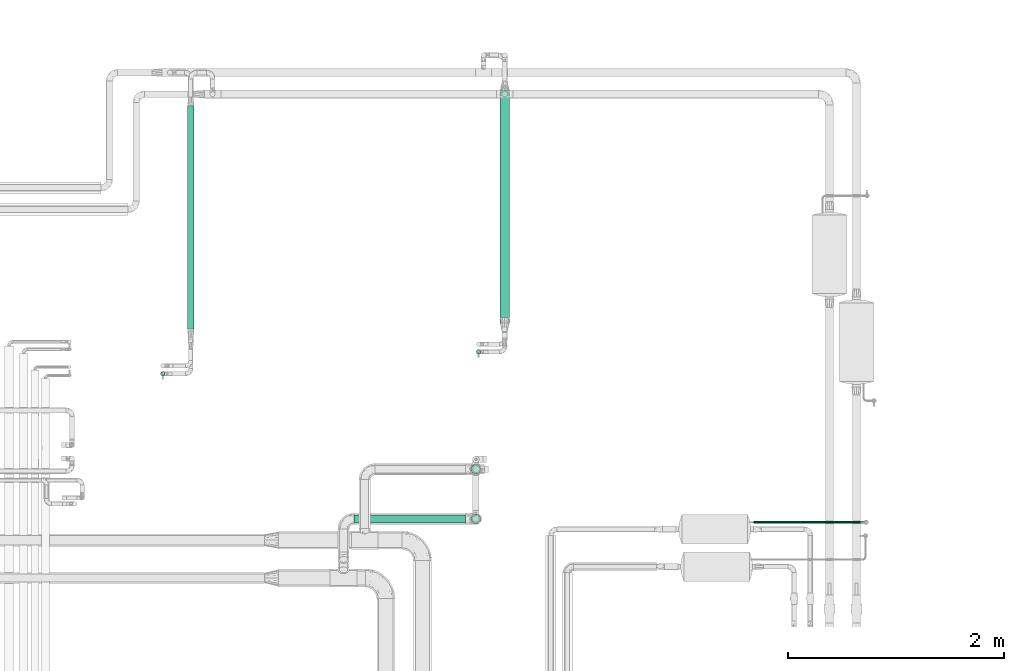
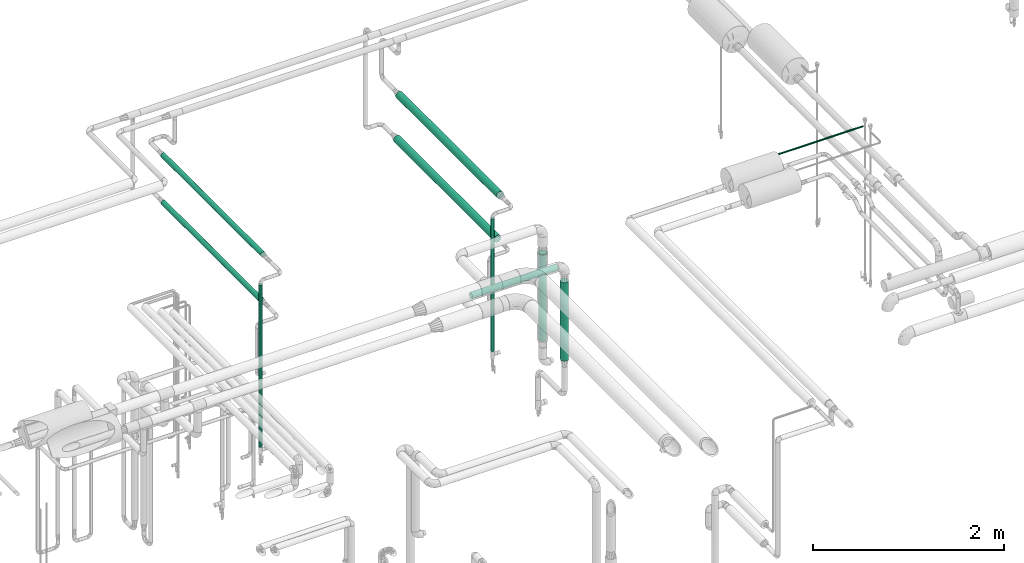
# One storey, part 527 of 827: 10 flow segments.
"""IFC2X3 building model written with IfcOpenShell, lengths in millimetres."""

from ifc_helpers import new_model, entity, si_unit, converted_unit, derived_unit, direction, frame, origin, origin_2d_with_axis, place, context, subcontext, project, spatial, circle, extrude, type_object, element, save


model = new_model("IFC2X3")

# Units and contexts
model_context = context("Model", 3, precision=0.01, world=origin(), true_north=direction((6.12303176911189e-17, 1.0)))
body_context = subcontext(model_context, "Body", "Model", "MODEL_VIEW")
ifc_project = project(units=[si_unit("LENGTHUNIT", "METRE", prefix="MILLI"), si_unit("AREAUNIT", "SQUARE_METRE"), si_unit("VOLUMEUNIT", "CUBIC_METRE"), converted_unit("PLANEANGLEUNIT", "DEGREE", entity("IfcRatioMeasure", 0.0174532925199433), si_unit("PLANEANGLEUNIT", "RADIAN"), dimensions=[0, 0, 0, 0, 0, 0, 0]), si_unit("MASSUNIT", "GRAM", prefix="KILO"), derived_unit("MASSDENSITYUNIT", [(si_unit("MASSUNIT", "GRAM", prefix="KILO"), 1), (si_unit("LENGTHUNIT", "METRE"), -3)]), derived_unit("MOMENTOFINERTIAUNIT", [(si_unit("LENGTHUNIT", "METRE"), 4)]), si_unit("TIMEUNIT", "SECOND"), si_unit("FREQUENCYUNIT", "HERTZ"), si_unit("THERMODYNAMICTEMPERATUREUNIT", "DEGREE_CELSIUS"), derived_unit("THERMALTRANSMITTANCEUNIT", [(si_unit("MASSUNIT", "GRAM", prefix="KILO"), 1), (si_unit("THERMODYNAMICTEMPERATUREUNIT", "KELVIN"), -1), (si_unit("TIMEUNIT", "SECOND"), -3)]), derived_unit("VOLUMETRICFLOWRATEUNIT", [(si_unit("LENGTHUNIT", "METRE"), 3), (si_unit("TIMEUNIT", "SECOND"), -1)]), derived_unit("MASSFLOWRATEUNIT", [(si_unit("MASSUNIT", "GRAM", prefix="KILO"), 1), (si_unit("TIMEUNIT", "SECOND"), -1)]), derived_unit("ROTATIONALFREQUENCYUNIT", [(si_unit("TIMEUNIT", "SECOND"), -1)]), si_unit("ELECTRICCURRENTUNIT", "AMPERE"), si_unit("ELECTRICVOLTAGEUNIT", "VOLT"), si_unit("POWERUNIT", "WATT"), si_unit("FORCEUNIT", "NEWTON", prefix="KILO"), si_unit("ILLUMINANCEUNIT", "LUX"), si_unit("LUMINOUSFLUXUNIT", "LUMEN"), si_unit("LUMINOUSINTENSITYUNIT", "CANDELA"), derived_unit("USERDEFINED", [(si_unit("MASSUNIT", "GRAM", prefix="KILO"), -1), (si_unit("LENGTHUNIT", "METRE"), -2), (si_unit("TIMEUNIT", "SECOND"), 3), (si_unit("LUMINOUSFLUXUNIT", "LUMEN"), 1)]), derived_unit("LINEARVELOCITYUNIT", [(si_unit("LENGTHUNIT", "METRE"), 1), (si_unit("TIMEUNIT", "SECOND"), -1)]), si_unit("PRESSUREUNIT", "PASCAL"), derived_unit("USERDEFINED", [(si_unit("LENGTHUNIT", "METRE"), -2), (si_unit("MASSUNIT", "GRAM", prefix="KILO"), 1), (si_unit("TIMEUNIT", "SECOND"), -2)]), derived_unit("LINEARFORCEUNIT", [(si_unit("MASSUNIT", "GRAM", prefix="KILO"), 1), (si_unit("LENGTHUNIT", "METRE"), 1), (si_unit("TIMEUNIT", "SECOND"), -2), (si_unit("LENGTHUNIT", "METRE"), -1)]), derived_unit("PLANARFORCEUNIT", [(si_unit("MASSUNIT", "GRAM", prefix="KILO"), 1), (si_unit("LENGTHUNIT", "METRE"), 1), (si_unit("TIMEUNIT", "SECOND"), -2), (si_unit("LENGTHUNIT", "METRE"), -2)])], contexts=[model_context])

# Site, building, storey
site_placement = place(None, origin())
site = spatial("IfcSite", under=ifc_project, at=site_placement, CompositionType="ELEMENT")
building_placement = place(site_placement, origin())
building = spatial("IfcBuilding", under=site, at=building_placement, CompositionType="ELEMENT")
storey_placement = place(building_placement, frame((0.0, 0.0, 28200.0)))
storey = spatial("IfcBuildingStorey", under=building, at=storey_placement, Name="08", CompositionType="ELEMENT", Elevation=28200.0)

# Flow segments
pipe_segment_type = type_object("IfcPipeSegmentType", PredefinedType="NOTDEFINED")
flow_segment_1_placement = place(storey_placement, frame((19747.74, 16268.55, 477.5)))
element("IfcFlowSegment", 1, at=flow_segment_1_placement, inside=storey, type_object=pipe_segment_type, context=body_context, shape_type="SweptSolid", body=[
    extrude(circle(Radius=21.15, at=origin_2d_with_axis()), frame((22.75, 22.75, 0.0), z_axis=(0.0, 0.0, 1.0), x_axis=(-1.0, 0.0, 0.0)), (0.0, 0.0, 1.0), 2074.83074715792),
])
flow_segment_2_placement = place(storey_placement, frame((22670.89, 16471.77, 553.82)))
element("IfcFlowSegment", 2, at=flow_segment_2_placement, inside=storey, type_object=pipe_segment_type, context=body_context, shape_type="SweptSolid", body=[
    extrude(circle(Radius=21.15, at=origin_2d_with_axis()), frame((22.75, 22.75, 0.0)), (0.0, 0.0, 1.0), 1695.43871126385),
])
flow_segment_3_placement = place(storey_placement, frame((21538.56, 14907.9, 2560.65)))
element("IfcFlowSegment", 3, at=flow_segment_3_placement, inside=storey, type_object=pipe_segment_type, context=body_context, shape_type="SweptSolid", body=[
    extrude(circle(Radius=37.75, at=origin_2d_with_axis()), frame((0.0, 39.35, 39.35), z_axis=(1.0, 0.0, 0.0), x_axis=(0.0, -1.0, 0.0)), (0.0, 0.0, 1.0), 1035.89794397964),
])
flow_segment_4_placement = place(storey_placement, frame((25238.71, 14903.34, 3117.75)))
element("IfcFlowSegment", 4, at=flow_segment_4_placement, inside=storey, type_object=pipe_segment_type, context=body_context, shape_type="SweptSolid", body=[
    extrude(circle(Radius=10.65, at=origin_2d_with_axis()), frame((0.0, 12.25, 12.25), z_axis=(1.0, 0.0, 0.0), x_axis=(0.0, 1.0, 0.0)), (0.0, 0.0, 1.0), 1019.58795672273),
])
flow_segment_5_placement = place(storey_placement, frame((22623.61, 15361.4, 1369.89)))
element("IfcFlowSegment", 5, at=flow_segment_5_placement, inside=storey, type_object=pipe_segment_type, context=body_context, shape_type="SweptSolid", body=[
    extrude(circle(Radius=44.25, at=origin_2d_with_axis()), frame((45.85, 45.85, 0.0)), (0.0, 0.0, 1.0), 1110.0),
])
flow_segment_6_placement = place(storey_placement, frame((22890.62, 16761.47, 2251.42)))
element("IfcFlowSegment", 6, at=flow_segment_6_placement, inside=storey, type_object=pipe_segment_type, context=body_context, shape_type="SweptSolid", body=[
    extrude(circle(Radius=44.25, at=origin_2d_with_axis()), frame((45.85, 0.0, 45.85), z_axis=(0.0, 1.0, 0.0), x_axis=(-1.0, 0.0, 0.0)), (0.0, 0.0, 1.0), 2106.00000000002),
])
flow_segment_7_placement = place(storey_placement, frame((22890.62, 16811.3, 1661.21)))
element("IfcFlowSegment", 7, at=flow_segment_7_placement, inside=storey, type_object=pipe_segment_type, context=body_context, shape_type="SweptSolid", body=[
    extrude(circle(Radius=44.25, at=origin_2d_with_axis()), frame((45.85, 0.0, 45.85), z_axis=(0.0, 1.0, 0.0), x_axis=(-1.0, 0.0, 0.0)), (0.0, 0.0, 1.0), 2103.50000000002),
])
flow_segment_8_placement = place(storey_placement, frame((22623.61, 14901.4, 1394.55)))
element("IfcFlowSegment", 8, at=flow_segment_8_placement, inside=storey, type_object=pipe_segment_type, context=body_context, shape_type="SweptSolid", body=[
    extrude(circle(Radius=44.25, at=origin_2d_with_axis()), frame((45.85, 45.85, 0.0), z_axis=(0.0, 0.0, 1.0), x_axis=(-1.0, 0.0, 0.0)), (0.0, 0.0, 1.0), 1002.94382244957),
])
flow_segment_9_placement = place(storey_placement, frame((19997.75, 16707.56, 1967.38)))
element("IfcFlowSegment", 9, at=flow_segment_9_placement, inside=storey, type_object=pipe_segment_type, context=body_context, shape_type="SweptSolid", body=[
    extrude(circle(Radius=30.0, at=origin_2d_with_axis()), frame((31.6, 0.0, 31.6), z_axis=(0.0, 1.0, 0.0), x_axis=(1.0, 0.0, 0.0)), (0.0, 0.0, 1.0), 2064.24244951419),
])
flow_segment_10_placement = place(storey_placement, frame((19997.75, 16687.3, 2568.74)))
element("IfcFlowSegment", 10, at=flow_segment_10_placement, inside=storey, type_object=pipe_segment_type, context=body_context, shape_type="SweptSolid", body=[
    extrude(circle(Radius=30.0, at=origin_2d_with_axis()), frame((31.6, 0.0, 31.6), z_axis=(0.0, 1.0, 0.0), x_axis=(-1.0, 0.0, 0.0)), (0.0, 0.0, 1.0), 2090.31616196688),
])

save(model, "model.ifc")
